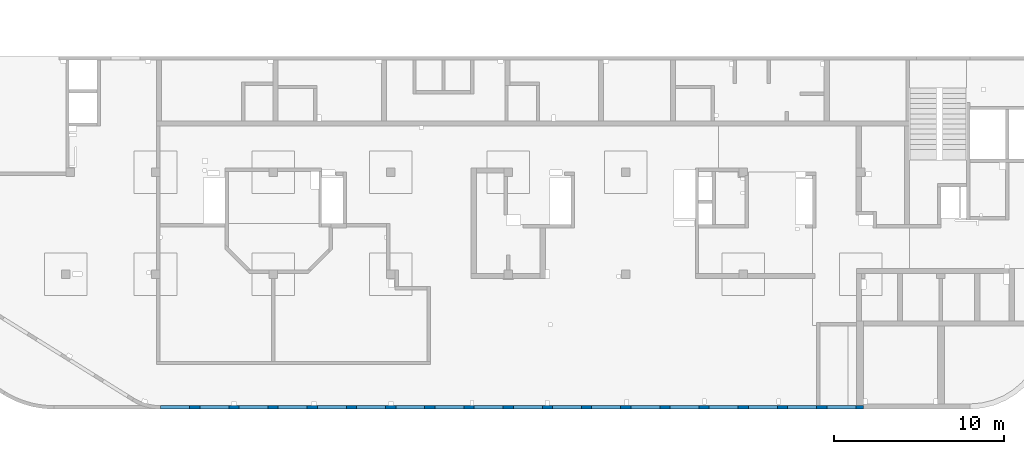
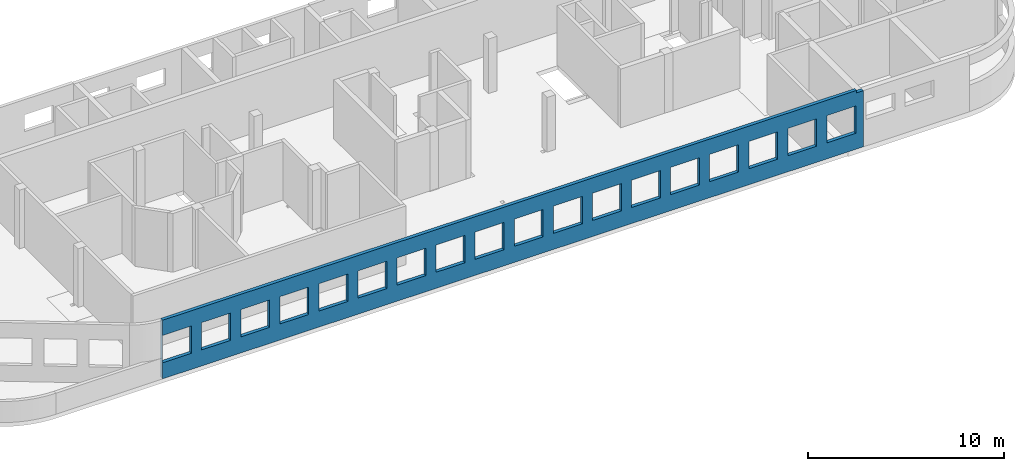
# One storey, part 8 of 10: 1 wall, 18 openings.
"""IFC4 building model written with IfcOpenShell, lengths in millimetres."""

from ifc_helpers import new_model, entity, si_unit, converted_unit, derived_unit, direction, frame, origin, place, context, subcontext, project, spatial, indexed_curve, outline, extrude, polygons, material, type_object, element, save


model = new_model("IFC4")

# Units and contexts
model_context = context("Model", 3, precision=0.01, world=origin(), true_north=direction((6.12303176911189e-17, 1.0)))
plan_context = context("Plan", 3, precision=0.01, world=origin(), true_north=direction((6.12303176911189e-17, 1.0)))
body_context = subcontext(model_context, "Body", "Model", "MODEL_VIEW")
ifc_project = project(units=[si_unit("LENGTHUNIT", "METRE", prefix="MILLI"), si_unit("AREAUNIT", "SQUARE_METRE"), si_unit("VOLUMEUNIT", "CUBIC_METRE"), converted_unit("PLANEANGLEUNIT", "DEGREE", entity("IfcRatioMeasure", 0.0174532925199433), si_unit("PLANEANGLEUNIT", "RADIAN"), dimensions=[0, 0, 0, 0, 0, 0, 0]), si_unit("MASSUNIT", "GRAM", prefix="KILO"), derived_unit("MASSDENSITYUNIT", [(si_unit("MASSUNIT", "GRAM", prefix="KILO"), 1), (si_unit("LENGTHUNIT", "METRE"), -3)]), derived_unit("MOMENTOFINERTIAUNIT", [(si_unit("LENGTHUNIT", "METRE"), 4)]), si_unit("TIMEUNIT", "SECOND"), si_unit("FREQUENCYUNIT", "HERTZ"), si_unit("THERMODYNAMICTEMPERATUREUNIT", "DEGREE_CELSIUS"), derived_unit("THERMALTRANSMITTANCEUNIT", [(si_unit("MASSUNIT", "GRAM", prefix="KILO"), 1), (si_unit("THERMODYNAMICTEMPERATUREUNIT", "KELVIN"), -1), (si_unit("TIMEUNIT", "SECOND"), -3)]), derived_unit("VOLUMETRICFLOWRATEUNIT", [(si_unit("LENGTHUNIT", "METRE"), 3), (si_unit("TIMEUNIT", "SECOND"), -1)]), derived_unit("MASSFLOWRATEUNIT", [(si_unit("MASSUNIT", "GRAM", prefix="KILO"), 1), (si_unit("TIMEUNIT", "SECOND"), -1)]), derived_unit("ROTATIONALFREQUENCYUNIT", [(si_unit("TIMEUNIT", "SECOND"), -1)]), si_unit("ELECTRICCURRENTUNIT", "AMPERE"), si_unit("ELECTRICVOLTAGEUNIT", "VOLT"), si_unit("POWERUNIT", "WATT"), si_unit("FORCEUNIT", "NEWTON", prefix="KILO"), si_unit("ILLUMINANCEUNIT", "LUX"), si_unit("LUMINOUSFLUXUNIT", "LUMEN"), si_unit("LUMINOUSINTENSITYUNIT", "CANDELA"), derived_unit("USERDEFINED", [(si_unit("MASSUNIT", "GRAM", prefix="KILO"), -1), (si_unit("LENGTHUNIT", "METRE"), -2), (si_unit("TIMEUNIT", "SECOND"), 3), (si_unit("LUMINOUSFLUXUNIT", "LUMEN"), 1)]), derived_unit("LINEARVELOCITYUNIT", [(si_unit("LENGTHUNIT", "METRE"), 1), (si_unit("TIMEUNIT", "SECOND"), -1)]), si_unit("PRESSUREUNIT", "PASCAL"), derived_unit("USERDEFINED", [(si_unit("LENGTHUNIT", "METRE"), -2), (si_unit("MASSUNIT", "GRAM", prefix="KILO"), 1), (si_unit("TIMEUNIT", "SECOND"), -2)]), derived_unit("LINEARFORCEUNIT", [(si_unit("MASSUNIT", "GRAM", prefix="KILO"), 1), (si_unit("LENGTHUNIT", "METRE"), 1), (si_unit("TIMEUNIT", "SECOND"), -2), (si_unit("LENGTHUNIT", "METRE"), -1)]), derived_unit("PLANARFORCEUNIT", [(si_unit("MASSUNIT", "GRAM", prefix="KILO"), 1), (si_unit("LENGTHUNIT", "METRE"), 1), (si_unit("TIMEUNIT", "SECOND"), -2), (si_unit("LENGTHUNIT", "METRE"), -2)])], contexts=[model_context, plan_context])

# Site, building, storey
site_placement = place(None, origin())
site = spatial("IfcSite", under=ifc_project, at=site_placement, CompositionType="ELEMENT")
building_placement = place(site_placement, origin())
building = spatial("IfcBuilding", under=site, at=building_placement, CompositionType="ELEMENT")
storey_placement = place(building_placement, frame((0.0, 0.0, 4200.0)))
storey = spatial("IfcBuildingStorey", under=building, at=storey_placement, CompositionType="ELEMENT", Elevation=4200.0)

# Wall, openings
ifc_material = material()
wall_type = type_object("IfcWallType", PredefinedType="STANDARD")
wall_placement = place(storey_placement, frame((21465.0002685546, -100.000773643746, -150.0)))
wall = element("IfcWall", 1, at=wall_placement, inside=storey, type_object=wall_type, material=ifc_material, PredefinedType="NOTDEFINED", context=body_context, shape_type="Tessellation", body=[
    polygons([(5.00000000005149, -100.0, 2700.0), (1705.00000000005, -100.0, 2700.0), (1705.00000000005, -100.0, 1000.00000000001), (5.00000000005149, -100.0, 1000.00000000001), (2305.00000000005, -100.0, 2700.0), (4005.00000000005, -100.0, 2700.0), (4005.00000000005, -100.0, 1000.00000000001), (2305.00000000005, -100.0, 1000.00000000001), (4605.00000000006, -100.0, 2700.0), (6305.00000000006, -100.0, 2700.0), (6305.00000000006, -100.0, 1000.00000000001), (4605.00000000006, -100.0, 1000.00000000001), (6905.00000000004, -100.0, 2700.0), (8605.00000000004, -100.0, 2700.0), (8605.00000000004, -100.0, 1000.00000000001), (6905.00000000004, -100.0, 1000.00000000001), (9205.00000000005, -100.0, 2700.0), (10905.0000000001, -100.0, 2700.0), (10905.0000000001, -100.0, 1000.00000000001), (9205.00000000005, -100.0, 1000.00000000001), (11505.0000000001, -100.0, 2700.0), (13205.0000000001, -100.0, 2700.0), (13205.0000000001, -100.0, 1000.00000000001), (11505.0000000001, -100.0, 1000.00000000001), (13805.0, -100.0, 2700.0), (15505.0, -100.0, 2700.0), (15505.0, -100.0, 1000.00000000001), (13805.0, -100.0, 1000.00000000001), (16105.0000000001, -100.0, 2700.0), (17805.0000000001, -100.0, 2700.0), (17805.0000000001, -100.0, 1000.00000000001), (16105.0000000001, -100.0, 1000.00000000001), (18405.0000000001, -100.0, 2700.0), (20105.0, -100.0, 2700.0), (20105.0, -100.0, 1000.00000000001), (18405.0000000001, -100.0, 1000.00000000001), (23005.0, -100.0, 2700.0), (24705.0, -100.0, 2700.0), (24705.0, -100.0, 1000.00000000001), (23005.0, -100.0, 1000.00000000001), (25305.0000000001, -100.0, 2700.0), (27005.0000000001, -100.0, 2700.0), (27005.0000000001, -100.0, 1000.00000000001), (25305.0000000001, -100.0, 1000.00000000001), (27605.0, -100.0, 2700.0), (29305.0, -100.0, 2700.0), (29305.0, -100.0, 1000.00000000001), (27605.0, -100.0, 1000.00000000001), (29905.0000000001, -100.0, 2700.0), (31605.0000000001, -100.0, 2700.0), (31605.0000000001, -100.0, 1000.00000000001), (29905.0000000001, -100.0, 1000.00000000001), (32205.0000000001, -100.0, 2700.0), (33905.0000000001, -100.0, 2700.0), (33905.0000000001, -100.0, 1000.00000000001), (32205.0000000001, -100.0, 1000.00000000001), (34505.0, -100.0, 2700.0), (36205.0, -100.0, 2700.0), (36205.0, -100.0, 1000.00000000001), (34505.0, -100.0, 1000.00000000001), (36805.0, -100.0, 2700.0), (38505.0000000001, -100.0, 2700.0), (38505.0000000001, -100.0, 1000.00000000001), (36805.0, -100.0, 1000.00000000001), (39105.0000000001, -100.0, 2700.0), (40805.0000000001, -100.0, 2700.0), (40805.0000000001, -100.0, 1000.00000000001), (39105.0000000001, -100.0, 1000.00000000001), (20705.0, -100.0, 2700.0), (22405.0, -100.0, 2700.0), (22405.0, -100.0, 1000.00000000001), (20705.0, -100.0, 1000.00000000001), (6.46057117472606e-13, -100.0, 5.41433564649196e-13), (40355.0, -100.0, 5.41433564649196e-13), (41255.0, -100.0, 5.41433564649196e-13), (41255.0, -100.0, 3500.0), (40855.0, -99.9999999999864, 3500.0), (40855.0, -100.0, 3650.0), (6.46057117472606e-13, -100.0, 3650.0), (6.46057117472606e-13, -100.0, 1310.0), (6.46057117472606e-13, -100.0, 150.000000000001), (41255.0, 100.0, 5.41433564649196e-13), (40855.0, 100.0, 5.41433564649196e-13), (38705.0, 100.0, 5.41433564649196e-13), (38505.0, 100.0, 5.41433564649196e-13), (22805.0, 100.0, 5.41433564649196e-13), (22605.0, 100.0, 5.41433564649196e-13), (18380.0, 100.0, 5.41433564649196e-13), (18180.0, 100.0, 5.41433564649196e-13), (13665.0, 100.0, 5.41433564649196e-13), (13365.0, 100.0, 5.41433564649196e-13), (9155.0, 100.0, 5.41433564649196e-13), (8855.0, 100.0, 5.41433564649196e-13), (4455.0, 100.0, 5.41433564649196e-13), (4155.0, 100.0, 5.41433564649196e-13), (2.49908057411173e-18, 100.0, 5.41433564649196e-13), (2.4990805740975e-18, 100.0, 150.000000000001), (2.4990805740975e-18, 100.0, 1310.0), (2.49908057411173e-18, 100.0, 3650.0), (13574.9996657992, 100.0, 3650.0), (13774.9996657992, 100.0, 3650.0), (18005.0, 100.0, 3650.0), (18205.0, 100.0, 3650.0), (38505.0, 100.0, 3650.0), (38705.0, 100.0, 3650.0), (40855.0, 100.0, 3650.0), (40855.0, 99.9999999999999, 3500.0), (41255.0, 100.0, 3500.0), (1705.00000000005, 100.000000000321, 2700.0), (5.00000000005084, 100.000000000321, 2700.0), (5.00000000005084, 100.000000000321, 1000.00000000001), (1705.00000000005, 100.000000000321, 1000.00000000001), (4005.00000000005, 100.000000000321, 2700.0), (2305.00000000005, 100.000000000321, 2700.0), (2305.00000000005, 100.000000000321, 1000.00000000001), (4005.00000000005, 100.000000000321, 1000.00000000001), (6305.00000000006, 100.000000000321, 2700.0), (4605.00000000006, 100.000000000321, 2700.0), (4605.00000000006, 100.000000000321, 1000.00000000001), (6305.00000000006, 100.000000000321, 1000.00000000001), (8605.00000000004, 100.000000000321, 2700.0), (6905.00000000004, 100.000000000321, 2700.0), (6905.00000000004, 100.000000000321, 1000.00000000001), (8605.00000000004, 100.000000000321, 1000.00000000001), (10905.0000000001, 100.000000000321, 2700.0), (9205.00000000005, 100.000000000321, 2700.0), (9205.00000000005, 100.000000000321, 1000.00000000001), (10905.0000000001, 100.000000000321, 1000.00000000001), (13205.0000000001, 100.000000000321, 2700.0), (11505.0000000001, 100.000000000321, 2700.0), (11505.0000000001, 100.000000000321, 1000.00000000001), (13205.0000000001, 100.000000000321, 1000.00000000001), (15505.0, 100.000000000321, 2700.0), (13805.0, 100.000000000321, 2700.0), (13805.0, 100.000000000321, 1000.00000000001), (15505.0, 100.000000000321, 1000.00000000001), (17805.0000000001, 100.000000000321, 2700.0), (16105.0000000001, 100.000000000321, 2700.0), (16105.0000000001, 100.000000000321, 1000.00000000001), (17805.0000000001, 100.000000000321, 1000.00000000001), (20105.0, 100.000000000321, 2700.0), (18405.0000000001, 100.000000000321, 2700.0), (18405.0000000001, 100.000000000321, 1000.00000000001), (20105.0, 100.000000000321, 1000.00000000001), (24705.0, 100.000000000321, 2700.0), (23005.0, 100.000000000321, 2700.0), (23005.0, 100.000000000321, 1000.00000000001), (24705.0, 100.000000000321, 1000.00000000001), (27005.0000000001, 100.000000000321, 2700.0), (25305.0000000001, 100.000000000321, 2700.0), (25305.0000000001, 100.000000000321, 1000.00000000001), (27005.0000000001, 100.000000000321, 1000.00000000001), (29305.0, 100.000000000321, 2700.0), (27605.0, 100.000000000321, 2700.0), (27605.0, 100.000000000321, 1000.00000000001), (29305.0, 100.000000000321, 1000.00000000001), (31605.0000000001, 100.000000000321, 2700.0), (29905.0000000001, 100.000000000321, 2700.0), (29905.0000000001, 100.000000000321, 1000.00000000001), (31605.0000000001, 100.000000000321, 1000.00000000001), (33905.0000000001, 100.000000000321, 2700.0), (32205.0000000001, 100.000000000321, 2700.0), (32205.0000000001, 100.000000000321, 1000.00000000001), (33905.0000000001, 100.000000000321, 1000.00000000001), (36205.0, 100.000000000321, 2700.0), (34505.0, 100.000000000321, 2700.0), (34505.0, 100.000000000321, 1000.00000000001), (36205.0, 100.000000000321, 1000.00000000001), (38505.0000000001, 100.000000000321, 2700.0), (36805.0, 100.000000000321, 2700.0), (36805.0, 100.000000000321, 1000.00000000001), (38505.0000000001, 100.000000000321, 1000.00000000001), (40805.0000000001, 100.000000000321, 2700.0), (39105.0000000001, 100.000000000321, 2700.0), (39105.0000000001, 100.000000000321, 1000.00000000001), (40805.0000000001, 100.000000000321, 1000.00000000001), (22405.0, 100.000000000321, 2700.0), (20705.0, 100.000000000321, 2700.0), (20705.0, 100.000000000321, 1000.00000000001), (22405.0, 100.000000000321, 1000.00000000001)], [[[73, 74, 75, 76, 77, 78, 79, 80, 81], [1, 2, 3, 4], [5, 6, 7, 8], [9, 10, 11, 12], [13, 14, 15, 16], [17, 18, 19, 20], [21, 22, 23, 24], [25, 26, 27, 28], [29, 30, 31, 32], [33, 34, 35, 36], [37, 38, 39, 40], [41, 42, 43, 44], [45, 46, 47, 48], [49, 50, 51, 52], [53, 54, 55, 56], [57, 58, 59, 60], [61, 62, 63, 64], [65, 66, 67, 68], [69, 70, 71, 72]], [[82, 83, 84, 85, 86, 87, 88, 89, 90, 91, 92, 93, 94, 95, 96, 97, 98, 99, 100, 101, 102, 103, 104, 105, 106, 107, 108], [109, 110, 111, 112], [113, 114, 115, 116], [117, 118, 119, 120], [121, 122, 123, 124], [125, 126, 127, 128], [129, 130, 131, 132], [133, 134, 135, 136], [137, 138, 139, 140], [141, 142, 143, 144], [145, 146, 147, 148], [149, 150, 151, 152], [153, 154, 155, 156], [157, 158, 159, 160], [161, 162, 163, 164], [165, 166, 167, 168], [169, 170, 171, 172], [173, 174, 175, 176], [177, 178, 179, 180]], [[75, 74, 73, 96, 95, 94, 93, 92, 91, 90, 89, 88, 87, 86, 85, 84, 83, 82]], [[99, 79, 78, 106, 105, 104, 103, 102, 101, 100]], [[75, 82, 108, 76]], [[110, 109, 2, 1]], [[110, 1, 4, 111]], [[111, 4, 3, 112]], [[2, 109, 112, 3]], [[114, 113, 6, 5]], [[114, 5, 8, 115]], [[115, 8, 7, 116]], [[6, 113, 116, 7]], [[118, 117, 10, 9]], [[118, 9, 12, 119]], [[119, 12, 11, 120]], [[10, 117, 120, 11]], [[122, 121, 14, 13]], [[122, 13, 16, 123]], [[123, 16, 15, 124]], [[14, 121, 124, 15]], [[126, 125, 18, 17]], [[126, 17, 20, 127]], [[127, 20, 19, 128]], [[18, 125, 128, 19]], [[130, 129, 22, 21]], [[130, 21, 24, 131]], [[131, 24, 23, 132]], [[22, 129, 132, 23]], [[134, 133, 26, 25]], [[134, 25, 28, 135]], [[135, 28, 27, 136]], [[26, 133, 136, 27]], [[138, 137, 30, 29]], [[138, 29, 32, 139]], [[139, 32, 31, 140]], [[30, 137, 140, 31]], [[142, 141, 34, 33]], [[142, 33, 36, 143]], [[143, 36, 35, 144]], [[34, 141, 144, 35]], [[146, 145, 38, 37]], [[146, 37, 40, 147]], [[147, 40, 39, 148]], [[38, 145, 148, 39]], [[150, 149, 42, 41]], [[150, 41, 44, 151]], [[151, 44, 43, 152]], [[42, 149, 152, 43]], [[154, 153, 46, 45]], [[154, 45, 48, 155]], [[155, 48, 47, 156]], [[46, 153, 156, 47]], [[158, 157, 50, 49]], [[158, 49, 52, 159]], [[159, 52, 51, 160]], [[50, 157, 160, 51]], [[162, 161, 54, 53]], [[162, 53, 56, 163]], [[163, 56, 55, 164]], [[54, 161, 164, 55]], [[166, 165, 58, 57]], [[166, 57, 60, 167]], [[167, 60, 59, 168]], [[58, 165, 168, 59]], [[170, 169, 62, 61]], [[170, 61, 64, 171]], [[171, 64, 63, 172]], [[62, 169, 172, 63]], [[174, 173, 66, 65]], [[174, 65, 68, 175]], [[175, 68, 67, 176]], [[66, 173, 176, 67]], [[178, 177, 70, 69]], [[178, 69, 72, 179]], [[179, 72, 71, 180]], [[70, 177, 180, 71]], [[79, 99, 98, 97, 96, 73, 81, 80]], [[107, 77, 76, 108]], [[77, 107, 106, 78]]], closed=True),
])
opening_1_placement = place(wall_placement, frame((-21465.0002685546, 100.000773643746, 150.0)))
element("IfcOpeningElement", 2, at=opening_1_placement, cuts=wall, PredefinedType="OPENING", context=body_context, shape_type="SweptSolid", body=[
    extrude(outline(indexed_curve([(-849.999999999994, -850.000000000006), (849.999999999993, -850.000000000006), (849.999999999993, 849.999999999997), (-849.999999999994, 849.999999999997), (-849.999999999994, -850.000000000006)], self_intersect=False)), frame((61420.0002685547, -200.000773643875, 1700.0), z_axis=(0.0, 1.0, 0.0), x_axis=(0.0, 0.0, -1.0)), (0.0, 0.0, 1.0), 200.000000000962),
])
opening_2_placement = place(wall_placement, frame((-21465.0002685546, 100.000773643746, 150.0)))
element("IfcOpeningElement", 3, at=opening_2_placement, cuts=wall, PredefinedType="OPENING", context=body_context, shape_type="SweptSolid", body=[
    extrude(outline(indexed_curve([(-849.999999999994, -849.999999999997), (849.999999999993, -849.999999999997), (849.999999999993, 850.000000000006), (-849.999999999994, 850.000000000006), (-849.999999999994, -849.999999999997)], self_intersect=False)), frame((59120.0002685547, -200.000773643867, 1700.0), z_axis=(0.0, 1.0, 0.0), x_axis=(0.0, 0.0, -1.0)), (0.0, 0.0, 1.0), 200.000000000962),
])
opening_3_placement = place(wall_placement, frame((-21465.0002685546, 100.000773643746, 150.0)))
element("IfcOpeningElement", 4, at=opening_3_placement, cuts=wall, PredefinedType="OPENING", context=body_context, shape_type="SweptSolid", body=[
    extrude(outline(indexed_curve([(-849.999999999994, -850.000000000006), (849.999999999993, -850.000000000006), (849.999999999993, 849.999999999997), (-849.999999999994, 849.999999999997), (-849.999999999994, -850.000000000006)], self_intersect=False)), frame((56820.0002685547, -200.00077364386, 1700.0), z_axis=(0.0, 1.0, 0.0), x_axis=(0.0, 0.0, -1.0)), (0.0, 0.0, 1.0), 200.000000000962),
])
opening_4_placement = place(wall_placement, frame((-21465.0002685546, 100.000773643746, 150.0)))
element("IfcOpeningElement", 5, at=opening_4_placement, cuts=wall, PredefinedType="OPENING", context=body_context, shape_type="SweptSolid", body=[
    extrude(outline(indexed_curve([(-849.999999999994, -849.999999999997), (849.999999999993, -849.999999999997), (849.999999999993, 850.000000000006), (-849.999999999994, 850.000000000006), (-849.999999999994, -849.999999999997)], self_intersect=False)), frame((54520.0002685547, -200.000773643852, 1700.0), z_axis=(0.0, 1.0, 0.0), x_axis=(0.0, 0.0, -1.0)), (0.0, 0.0, 1.0), 200.000000000962),
])
opening_5_placement = place(wall_placement, frame((-21465.0002685546, 100.000773643746, 150.0)))
element("IfcOpeningElement", 6, at=opening_5_placement, cuts=wall, PredefinedType="OPENING", context=body_context, shape_type="SweptSolid", body=[
    extrude(outline(indexed_curve([(-849.999999999994, -849.999999999997), (849.999999999993, -849.999999999997), (849.999999999993, 850.000000000006), (-849.999999999994, 850.000000000006), (-849.999999999994, -849.999999999997)], self_intersect=False)), frame((52220.0002685547, -200.000773643845, 1700.0), z_axis=(0.0, 1.0, 0.0), x_axis=(0.0, 0.0, -1.0)), (0.0, 0.0, 1.0), 200.000000000962),
])
opening_6_placement = place(wall_placement, frame((-21465.0002685546, 100.000773643746, 150.0)))
element("IfcOpeningElement", 7, at=opening_6_placement, cuts=wall, PredefinedType="OPENING", context=body_context, shape_type="SweptSolid", body=[
    extrude(outline(indexed_curve([(-849.999999999994, -850.000000000006), (849.999999999993, -850.000000000006), (849.999999999993, 849.999999999997), (-849.999999999994, 849.999999999997), (-849.999999999994, -850.000000000006)], self_intersect=False)), frame((49920.0002685547, -200.000773643838, 1700.0), z_axis=(0.0, 1.0, 0.0), x_axis=(0.0, 0.0, -1.0)), (0.0, 0.0, 1.0), 200.000000000962),
])
opening_7_placement = place(wall_placement, frame((-21465.0002685546, 100.000773643746, 150.0)))
element("IfcOpeningElement", 8, at=opening_7_placement, cuts=wall, PredefinedType="OPENING", context=body_context, shape_type="SweptSolid", body=[
    extrude(outline(indexed_curve([(-849.999999999994, -849.999999999997), (849.999999999993, -849.999999999997), (849.999999999993, 850.000000000006), (-849.999999999994, 850.000000000006), (-849.999999999994, -849.999999999997)], self_intersect=False)), frame((47620.0002685547, -200.00077364383, 1700.0), z_axis=(0.0, 1.0, 0.0), x_axis=(0.0, 0.0, -1.0)), (0.0, 0.0, 1.0), 200.000000000962),
])
opening_8_placement = place(wall_placement, frame((-21465.0002685546, 100.000773643746, 150.0)))
element("IfcOpeningElement", 9, at=opening_8_placement, cuts=wall, PredefinedType="OPENING", context=body_context, shape_type="SweptSolid", body=[
    extrude(outline(indexed_curve([(-849.999999999994, -850.000000000006), (849.999999999993, -850.000000000006), (849.999999999993, 849.999999999997), (-849.999999999994, 849.999999999997), (-849.999999999994, -850.000000000006)], self_intersect=False)), frame((45320.0002685547, -200.000773643823, 1700.0), z_axis=(0.0, 1.0, 0.0), x_axis=(0.0, 0.0, -1.0)), (0.0, 0.0, 1.0), 200.000000000962),
])
opening_9_placement = place(wall_placement, frame((-21465.0002685546, 100.000773643746, 150.0)))
element("IfcOpeningElement", 10, at=opening_9_placement, cuts=wall, PredefinedType="OPENING", context=body_context, shape_type="SweptSolid", body=[
    extrude(outline(indexed_curve([(-849.999999999994, -850.000000000006), (849.999999999993, -850.000000000006), (849.999999999993, 849.999999999997), (-849.999999999994, 849.999999999997), (-849.999999999994, -850.000000000006)], self_intersect=False)), frame((40720.0002685547, -200.000773643808, 1700.0), z_axis=(0.0, 1.0, 0.0), x_axis=(0.0, 0.0, -1.0)), (0.0, 0.0, 1.0), 200.000000000962),
])
opening_10_placement = place(wall_placement, frame((-21465.0002685546, 100.000773643746, 150.0)))
element("IfcOpeningElement", 11, at=opening_10_placement, cuts=wall, PredefinedType="OPENING", context=body_context, shape_type="SweptSolid", body=[
    extrude(outline(indexed_curve([(-849.999999999994, -850.000000000002), (849.999999999993, -850.000000000002), (849.999999999993, 849.999999999997), (-849.999999999994, 849.999999999997), (-849.999999999994, -850.000000000002)], self_intersect=False)), frame((38420.0002685547, -200.0007736438, 1700.0), z_axis=(0.0, 1.0, 0.0), x_axis=(0.0, 0.0, -1.0)), (0.0, 0.0, 1.0), 200.000000000962),
])
opening_11_placement = place(wall_placement, frame((-21465.0002685546, 100.000773643746, 150.0)))
element("IfcOpeningElement", 12, at=opening_11_placement, cuts=wall, PredefinedType="OPENING", context=body_context, shape_type="SweptSolid", body=[
    extrude(outline(indexed_curve([(-849.999999999994, -850.000000000002), (849.999999999993, -850.000000000002), (849.999999999993, 849.999999999997), (-849.999999999994, 849.999999999997), (-849.999999999994, -850.000000000002)], self_intersect=False)), frame((36120.0002685547, -200.000773643793, 1700.0), z_axis=(0.0, 1.0, 0.0), x_axis=(0.0, 0.0, -1.0)), (0.0, 0.0, 1.0), 200.000000000962),
])
opening_12_placement = place(wall_placement, frame((-21465.0002685546, 100.000773643746, 150.0)))
element("IfcOpeningElement", 13, at=opening_12_placement, cuts=wall, PredefinedType="OPENING", context=body_context, shape_type="SweptSolid", body=[
    extrude(outline(indexed_curve([(-849.999999999994, -850.000000000002), (849.999999999993, -850.000000000002), (849.999999999993, 849.999999999997), (-849.999999999994, 849.999999999997), (-849.999999999994, -850.000000000002)], self_intersect=False)), frame((33820.0002685547, -200.000773643785, 1700.0), z_axis=(0.0, 1.0, 0.0), x_axis=(0.0, 0.0, -1.0)), (0.0, 0.0, 1.0), 200.000000000962),
])
opening_13_placement = place(wall_placement, frame((-21465.0002685546, 100.000773643746, 150.0)))
element("IfcOpeningElement", 14, at=opening_13_placement, cuts=wall, PredefinedType="OPENING", context=body_context, shape_type="SweptSolid", body=[
    extrude(outline(indexed_curve([(-849.999999999994, -849.999999999997), (849.999999999993, -849.999999999997), (849.999999999993, 850.000000000002), (-849.999999999994, 850.000000000002), (-849.999999999994, -849.999999999997)], self_intersect=False)), frame((31520.0002685547, -200.000773643778, 1700.0), z_axis=(0.0, 1.0, 0.0), x_axis=(0.0, 0.0, -1.0)), (0.0, 0.0, 1.0), 200.000000000962),
])
opening_14_placement = place(wall_placement, frame((-21465.0002685546, 100.000773643746, 150.0)))
element("IfcOpeningElement", 15, at=opening_14_placement, cuts=wall, PredefinedType="OPENING", context=body_context, shape_type="SweptSolid", body=[
    extrude(outline(indexed_curve([(-849.999999999994, -849.999999999997), (849.999999999993, -849.999999999997), (849.999999999993, 850.000000000002), (-849.999999999994, 850.000000000002), (-849.999999999994, -849.999999999997)], self_intersect=False)), frame((29220.0002685547, -200.000773643771, 1700.0), z_axis=(0.0, 1.0, 0.0), x_axis=(0.0, 0.0, -1.0)), (0.0, 0.0, 1.0), 200.000000000962),
])
opening_15_placement = place(wall_placement, frame((-21465.0002685546, 100.000773643746, 150.0)))
element("IfcOpeningElement", 16, at=opening_15_placement, cuts=wall, PredefinedType="OPENING", context=body_context, shape_type="SweptSolid", body=[
    extrude(outline(indexed_curve([(-849.999999999994, -850.000000000002), (849.999999999993, -850.000000000002), (849.999999999993, 849.999999999997), (-849.999999999994, 849.999999999997), (-849.999999999994, -850.000000000002)], self_intersect=False)), frame((26920.0002685547, -200.000773643763, 1700.0), z_axis=(0.0, 1.0, 0.0), x_axis=(0.0, 0.0, -1.0)), (0.0, 0.0, 1.0), 200.000000000962),
])
opening_16_placement = place(wall_placement, frame((-21465.0002685546, 100.000773643746, 150.0)))
element("IfcOpeningElement", 17, at=opening_16_placement, cuts=wall, PredefinedType="OPENING", context=body_context, shape_type="SweptSolid", body=[
    extrude(outline(indexed_curve([(-849.999999999994, -850.000000000002), (849.999999999993, -850.000000000002), (849.999999999993, 849.999999999997), (-849.999999999994, 849.999999999997), (-849.999999999994, -850.000000000002)], self_intersect=False)), frame((24620.0002685547, -200.000773643756, 1700.0), z_axis=(0.0, 1.0, 0.0), x_axis=(0.0, 0.0, -1.0)), (0.0, 0.0, 1.0), 200.000000000962),
])
opening_17_placement = place(wall_placement, frame((-21465.0002685546, 100.000773643746, 150.0)))
element("IfcOpeningElement", 18, at=opening_17_placement, cuts=wall, PredefinedType="OPENING", context=body_context, shape_type="SweptSolid", body=[
    extrude(outline(indexed_curve([(-849.999999999994, -850.000000000002), (849.999999999993, -850.000000000002), (849.999999999993, 849.999999999997), (-849.999999999994, 849.999999999997), (-849.999999999994, -850.000000000002)], self_intersect=False)), frame((22320.0002685547, -200.000773643748, 1700.0), z_axis=(0.0, 1.0, 0.0), x_axis=(0.0, 0.0, -1.0)), (0.0, 0.0, 1.0), 200.000000000962),
])
opening_18_placement = place(wall_placement, frame((-21465.0002685546, 100.000773643746, 150.0)))
element("IfcOpeningElement", 19, at=opening_18_placement, cuts=wall, PredefinedType="OPENING", context=body_context, shape_type="SweptSolid", body=[
    extrude(outline(indexed_curve([(-849.999999999994, -849.999999999997), (849.999999999993, -849.999999999997), (849.999999999993, 850.000000000006), (-849.999999999994, 850.000000000006), (-849.999999999994, -849.999999999997)], self_intersect=False)), frame((43020.0002685547, -200.000773643815, 1700.0), z_axis=(0.0, 1.0, 0.0), x_axis=(0.0, 0.0, -1.0)), (0.0, 0.0, 1.0), 200.000000000962),
])

save(model, "model.ifc")
